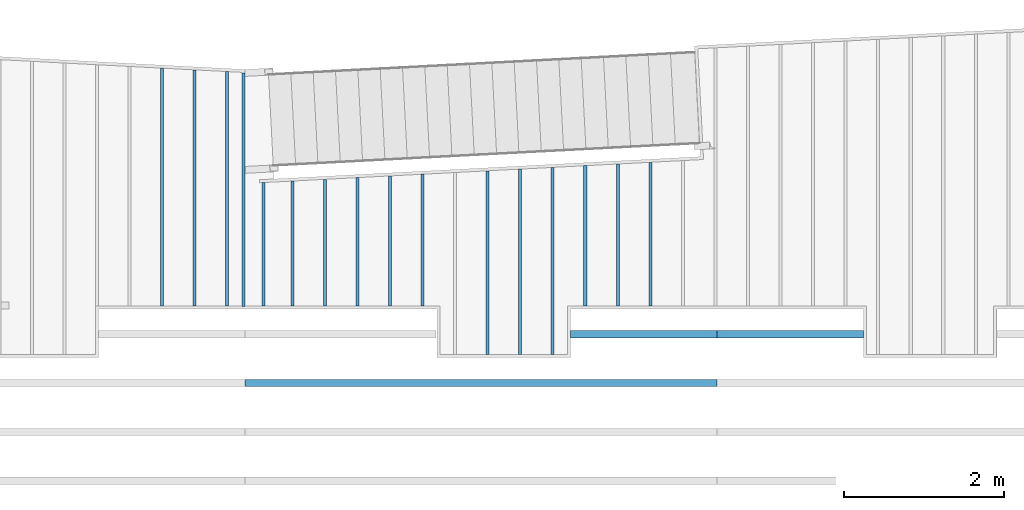
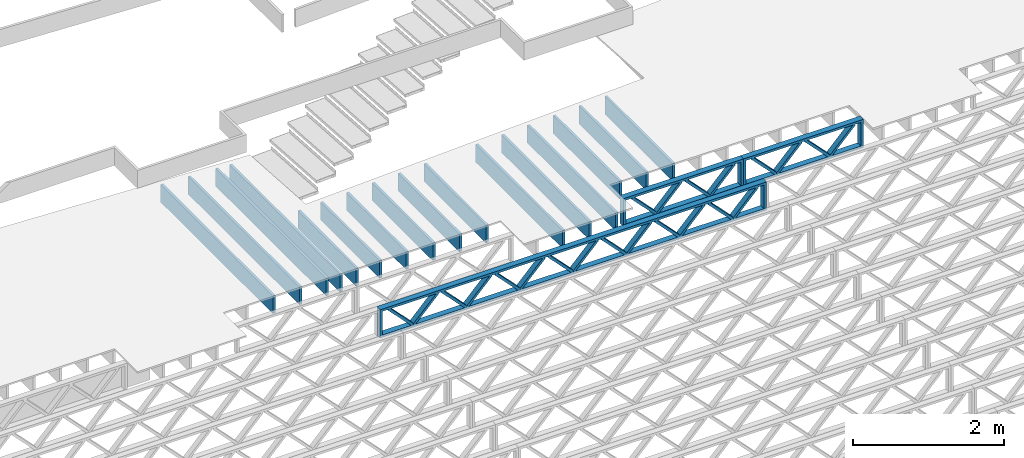
# One storey, part 5 of 23: 19 beams, 3 elements without a shape of their own.
"""IFC4 building model written with IfcOpenShell, lengths in feet."""

from ifc_helpers import new_model, entity, si_unit, converted_unit, derived_unit, direction, frame, frame_2d, origin, origin_2d_with_axis, place, context, subcontext, project, spatial, rectangle, extrude, source, transform, mapped, material, material_profile, profile_set, profile_usage, type_object, type_shapes, element, aggregate, save


model = new_model("IFC4")

# Units and contexts
model_context = context("Model", 3, precision=0.0001, world=origin(), true_north=direction((6.12303176911189e-17, 1.0)))
body_context = subcontext(model_context, "Body", "Model", "MODEL_VIEW")
ifc_project = project(units=[converted_unit("LENGTHUNIT", "FOOT", entity("IfcRatioMeasure", 0.3048), si_unit("LENGTHUNIT", "METRE"), dimensions=[1, 0, 0, 0, 0, 0, 0]), converted_unit("AREAUNIT", "SQUARE FOOT", entity("IfcRatioMeasure", 0.09290304), si_unit("AREAUNIT", "SQUARE_METRE"), dimensions=[2, 0, 0, 0, 0, 0, 0]), converted_unit("VOLUMEUNIT", "CUBIC FOOT", entity("IfcRatioMeasure", 0.028316846592), si_unit("VOLUMEUNIT", "CUBIC_METRE"), dimensions=[3, 0, 0, 0, 0, 0, 0]), converted_unit("PLANEANGLEUNIT", "DEGREE", entity("IfcRatioMeasure", 0.0174532925199433), si_unit("PLANEANGLEUNIT", "RADIAN"), dimensions=[0, 0, 0, 0, 0, 0, 0]), si_unit("MASSUNIT", "GRAM", prefix="KILO"), derived_unit("MASSDENSITYUNIT", [(si_unit("MASSUNIT", "GRAM", prefix="KILO"), 1), (si_unit("LENGTHUNIT", "METRE"), -3)]), derived_unit("MOMENTOFINERTIAUNIT", [(si_unit("LENGTHUNIT", "METRE"), 4)]), si_unit("TIMEUNIT", "SECOND"), si_unit("FREQUENCYUNIT", "HERTZ"), si_unit("THERMODYNAMICTEMPERATUREUNIT", "DEGREE_CELSIUS"), derived_unit("THERMALTRANSMITTANCEUNIT", [(si_unit("MASSUNIT", "GRAM", prefix="KILO"), 1), (si_unit("THERMODYNAMICTEMPERATUREUNIT", "KELVIN"), -1), (si_unit("TIMEUNIT", "SECOND"), -3)]), derived_unit("VOLUMETRICFLOWRATEUNIT", [(si_unit("LENGTHUNIT", "METRE"), 3), (si_unit("TIMEUNIT", "SECOND"), -1)]), si_unit("ELECTRICCURRENTUNIT", "AMPERE"), si_unit("ELECTRICVOLTAGEUNIT", "VOLT"), si_unit("POWERUNIT", "WATT"), si_unit("FORCEUNIT", "NEWTON"), si_unit("ILLUMINANCEUNIT", "LUX"), si_unit("LUMINOUSFLUXUNIT", "LUMEN"), si_unit("LUMINOUSINTENSITYUNIT", "CANDELA"), derived_unit("USERDEFINED", [(si_unit("MASSUNIT", "GRAM", prefix="KILO"), -1), (si_unit("LENGTHUNIT", "METRE"), -2), (si_unit("TIMEUNIT", "SECOND"), 3), (si_unit("LUMINOUSFLUXUNIT", "LUMEN"), 1)]), derived_unit("LINEARVELOCITYUNIT", [(si_unit("LENGTHUNIT", "METRE"), 1), (si_unit("TIMEUNIT", "SECOND"), -1)]), si_unit("PRESSUREUNIT", "PASCAL"), derived_unit("USERDEFINED", [(si_unit("LENGTHUNIT", "METRE"), -2), (si_unit("MASSUNIT", "GRAM", prefix="KILO"), 1), (si_unit("TIMEUNIT", "SECOND"), -2)]), derived_unit("LINEARFORCEUNIT", [(si_unit("MASSUNIT", "GRAM", prefix="KILO"), 1), (si_unit("LENGTHUNIT", "METRE"), 1), (si_unit("TIMEUNIT", "SECOND"), -2), (si_unit("LENGTHUNIT", "METRE"), -1)]), derived_unit("PLANARFORCEUNIT", [(si_unit("MASSUNIT", "GRAM", prefix="KILO"), 1), (si_unit("LENGTHUNIT", "METRE"), 1), (si_unit("TIMEUNIT", "SECOND"), -2), (si_unit("LENGTHUNIT", "METRE"), -2)])], contexts=[model_context])

# Site, building, storey
site_placement = place(None, origin())
site = spatial("IfcSite", under=ifc_project, at=site_placement, CompositionType="ELEMENT")
building_placement = place(site_placement, origin())
building = spatial("IfcBuilding", under=site, at=building_placement, CompositionType="ELEMENT")
storey_placement = place(building_placement, frame((0.0, 0.0, 10.8020833333333)))
storey = spatial("IfcBuildingStorey", under=building, at=storey_placement, Name="2ND FLOOR", CompositionType="ELEMENT", Elevation=10.8020833333333)

# Assembly, beams
assembly_1_placement = place(storey_placement, origin())
assembly_1 = element("IfcElementAssembly", 1, at=assembly_1_placement, inside=storey, Name="Structural Beam System:Structural Framing System", ObjectType="Structural Beam System:Structural Framing System", AssemblyPlace="NOTDEFINED", PredefinedType="BEAM_GRID")
ifc_material_1 = material(Name="WOOD TRUSS", Category="Materials")
ifc_material_profile_1 = material_profile(ifc_material_1, rectangle(XDim=1.73473973950632, YDim=0.125, at=frame_2d((-1.11022302462516e-16, 8.32667268468867e-17), x_axis=(1.0, 0.0))))
ifc_material_profile_2 = material_profile(ifc_material_1, rectangle(XDim=1.73473973950633, YDim=0.125, at=frame_2d((-1.11022302462516e-16, 8.32667268468867e-17), x_axis=(1.0, 0.0))))
ifc_material_profile_3 = material_profile(ifc_material_1, rectangle(XDim=1.73473973950632, YDim=0.125, at=frame_2d((-5.55111512312578e-17, 1.38777878078145e-16), x_axis=(1.0, 0.0))))
ifc_material_profile_4 = material_profile(ifc_material_1, rectangle(XDim=1.73473973950633, YDim=0.125, at=frame_2d((-1.11022302462516e-16, 8.32667268468867e-17), x_axis=(1.0, 0.0))))
ifc_material_profile_5 = material_profile(ifc_material_1, rectangle(XDim=1.73473973950632, YDim=0.125, at=frame_2d((-1.11022302462516e-16, 8.32667268468867e-17), x_axis=(1.0, 0.0))))
ifc_material_profile_6 = material_profile(ifc_material_1, rectangle(XDim=1.73473973950633, YDim=0.125, at=frame_2d((-2.77555756156289e-16, 3.05311331771918e-16), x_axis=(1.0, 0.0))))
ifc_material_profile_7 = material_profile(ifc_material_1, rectangle(XDim=1.73473973950632, YDim=0.124999999999999, at=frame_2d((-3.88578058618805e-16, -2.4980018054066e-16), x_axis=(1.0, 0.0))))
ifc_material_profile_8 = material_profile(ifc_material_1, rectangle(XDim=1.73473973950633, YDim=0.125, at=frame_2d((2.77555756156289e-16, -3.05311331771918e-16), x_axis=(1.0, 0.0))))
ifc_material_profile_9 = material_profile(ifc_material_1, rectangle(XDim=1.73473973950632, YDim=0.124999999999999, at=frame_2d((-1.11022302462516e-16, 8.32667268468867e-17), x_axis=(1.0, 0.0))))
ifc_material_profile_10 = material_profile(ifc_material_1, rectangle(XDim=1.73473973950633, YDim=0.125, at=origin_2d_with_axis()))
ifc_material_profile_11 = material_profile(ifc_material_1, rectangle(XDim=0.124999999999982, YDim=0.291666666666668, at=origin_2d_with_axis()))
ifc_material_profile_12 = material_profile(ifc_material_1, rectangle(XDim=0.124999999999932, YDim=0.291666666666664, at=origin_2d_with_axis()))
ifc_material_profile_13 = material_profile(ifc_material_1, rectangle(XDim=1.25000000000002, YDim=0.29166666666667, at=origin_2d_with_axis()))
ifc_material_profile_14 = material_profile(ifc_material_1, rectangle(XDim=1.25000000000004, YDim=0.291666666666667, at=origin_2d_with_axis()))
ifc_profile_set_1 = profile_set([ifc_material_profile_1, ifc_material_profile_2, ifc_material_profile_3, ifc_material_profile_4, ifc_material_profile_5, ifc_material_profile_6, ifc_material_profile_7, ifc_material_profile_8, ifc_material_profile_9, ifc_material_profile_10, ifc_material_profile_11, ifc_material_profile_12, ifc_material_profile_13, ifc_material_profile_14])
ifc_profile_usage_1 = profile_usage(ifc_profile_set_1, cardinal=8)
beam_type_1 = type_object("IfcBeamType", PredefinedType="BEAM", material=ifc_profile_set_1)
shared_shape_1 = source(origin(), body_context, "Body", "SweptSolid", [
    extrude(rectangle(XDim=1.73473973950632, YDim=0.125, at=frame_2d((0.0, 1.66533453693773e-16), x_axis=(1.0, 0.0))), frame((1.95847612494153, -0.145833333333334, 0.0), z_axis=(0.0, 1.0, 0.0), x_axis=(0.693383046997606, 0.0, 0.720569184836762)), (0.0, 0.0, 1.0), 0.291666666666667),
    extrude(rectangle(XDim=1.73473973950633, YDim=0.125, at=frame_2d((-5.55111512312578e-17, 8.32667268468867e-17), x_axis=(1.0, 0.0))), frame((0.708190251268258, -0.145833333333334, 0.0), z_axis=(0.0, 1.0, 0.0), x_axis=(0.69338304699761, 0.0, -0.720569184836758)), (0.0, 0.0, 1.0), 0.291666666666667),
    extrude(rectangle(XDim=1.73473973950632, YDim=0.125, at=frame_2d((0.0, 1.66533453693773e-16), x_axis=(1.0, 0.0))), frame((-0.708190251267602, -0.145833333333334, 0.0), z_axis=(0.0, 1.0, 0.0), x_axis=(0.693383046997606, 0.0, 0.720569184836762)), (0.0, 0.0, 1.0), 0.291666666666667),
    extrude(rectangle(XDim=1.73473973950633, YDim=0.125, at=frame_2d((-2.22044604925031e-16, 2.22044604925031e-16), x_axis=(1.0, 0.0))), frame((-1.95847612494087, -0.145833333333334, 0.0), z_axis=(0.0, 1.0, 0.0), x_axis=(0.69338304699761, 0.0, -0.720569184836758)), (0.0, 0.0, 1.0), 0.291666666666666),
    extrude(rectangle(XDim=0.124999999999982, YDim=0.291666666666668, at=origin_2d_with_axis()), frame((-2.99999985477115, 0.0, 0.687500000000054), z_axis=(1.0, 0.0, 0.0), x_axis=(0.0, 0.0, -1.0)), (0.0, 0.0, 1.0), 5.99999970954229),
    extrude(rectangle(XDim=0.124999999999932, YDim=0.291666666666664, at=origin_2d_with_axis()), frame((-2.99999985477093, 0.0, -0.687499999999984), z_axis=(1.0, 0.0, 0.0), x_axis=(0.0, 0.0, -1.0)), (0.0, 0.0, 1.0), 5.99999970954208),
    extrude(rectangle(XDim=1.25000000000002, YDim=0.29166666666667, at=origin_2d_with_axis()), frame((2.87499985477113, 0.0, 0.0), z_axis=(1.0, 0.0, 0.0), x_axis=(0.0, 0.0, -1.0)), (0.0, 0.0, 1.0), 0.12500000000002),
    extrude(rectangle(XDim=1.25000000000004, YDim=0.291666666666667, at=origin_2d_with_axis()), frame((-2.99999985477115, 0.0, 0.0), z_axis=(1.0, 0.0, 0.0), x_axis=(0.0, 0.0, -1.0)), (0.0, 0.0, 1.0), 0.125000000000023),
])
type_shapes(beam_type_1, [shared_shape_1])
beam_1_placement = place(assembly_1_placement, frame((-225.404826976829, 957.861934882651, -0.947916666666648)))
beam_1 = element("IfcBeam", 2, at=beam_1_placement, type_object=beam_type_1, material=ifc_profile_usage_1, PredefinedType="BEAM", context=body_context, shape_type="MappedRepresentation", body=[
    mapped(shared_shape_1, transform((0.0, 0.0, 0.0), scale=1.0)),
])
ifc_profile_usage_2 = profile_usage(ifc_profile_set_1, cardinal=8)
beam_type_2 = type_object("IfcBeamType", PredefinedType="BEAM", material=ifc_profile_set_1)
shared_shape_2 = source(origin(), body_context, "Body", "SweptSolid", [
    extrude(rectangle(XDim=1.73473973950632, YDim=0.124999999999999, at=frame_2d((5.55111512312578e-16, 7.21644966006352e-16), x_axis=(1.0, 0.0))), frame((5.95847627016997, -0.145833333333334, 0.0), z_axis=(0.0, 1.0, 0.0), x_axis=(0.693383046997606, 0.0, 0.720569184836762)), (0.0, 0.0, 1.0), 0.291666666666667),
    extrude(rectangle(XDim=1.73473973950633, YDim=0.125, at=origin_2d_with_axis()), frame((4.7081903964967, -0.145833333333334, 0.0), z_axis=(0.0, 1.0, 0.0), x_axis=(0.69338304699761, 0.0, -0.720569184836758)), (0.0, 0.0, 1.0), 0.291666666666666),
    extrude(rectangle(XDim=1.73473973950632, YDim=0.125, at=frame_2d((2.22044604925031e-16, 3.88578058618805e-16), x_axis=(1.0, 0.0))), frame((3.29180960350347, -0.145833333333334, 0.0), z_axis=(0.0, 1.0, 0.0), x_axis=(0.693383046997606, 0.0, 0.720569184836762)), (0.0, 0.0, 1.0), 0.291666666666667),
    extrude(rectangle(XDim=1.73473973950633, YDim=0.125, at=frame_2d((1.11022302462516e-16, -8.32667268468867e-17), x_axis=(1.0, 0.0))), frame((2.0415237298302, -0.145833333333334, 0.0), z_axis=(0.0, 1.0, 0.0), x_axis=(0.69338304699761, 0.0, -0.720569184836758)), (0.0, 0.0, 1.0), 0.291666666666667),
    extrude(rectangle(XDim=1.73473973950632, YDim=0.125, at=frame_2d((-5.55111512312578e-17, 1.38777878078145e-16), x_axis=(1.0, 0.0))), frame((0.625142936836964, -0.145833333333334, 0.0), z_axis=(0.0, 1.0, 0.0), x_axis=(0.693383046997606, 0.0, 0.720569184836762)), (0.0, 0.0, 1.0), 0.291666666666667),
    extrude(rectangle(XDim=1.73473973950633, YDim=0.125, at=frame_2d((-1.11022302462516e-16, 8.32667268468867e-17), x_axis=(1.0, 0.0))), frame((-0.625142936836306, -0.145833333333334, 0.0), z_axis=(0.0, 1.0, 0.0), x_axis=(0.69338304699761, 0.0, -0.720569184836758)), (0.0, 0.0, 1.0), 0.291666666666667),
    extrude(rectangle(XDim=1.73473973950632, YDim=0.125, at=frame_2d((-1.11022302462516e-16, 8.32667268468867e-17), x_axis=(1.0, 0.0))), frame((-2.04152372982954, -0.145833333333334, 0.0), z_axis=(0.0, 1.0, 0.0), x_axis=(0.693383046997606, 0.0, 0.720569184836762)), (0.0, 0.0, 1.0), 0.291666666666667),
    extrude(rectangle(XDim=1.73473973950633, YDim=0.125, at=origin_2d_with_axis()), frame((-3.29180960350281, -0.145833333333334, 0.0), z_axis=(0.0, 1.0, 0.0), x_axis=(0.69338304699761, 0.0, -0.720569184836758)), (0.0, 0.0, 1.0), 0.291666666666667),
    extrude(rectangle(XDim=1.73473973950632, YDim=0.124999999999999, at=frame_2d((-1.11022302462516e-16, 8.32667268468867e-17), x_axis=(1.0, 0.0))), frame((-4.70819039649604, -0.145833333333334, 0.0), z_axis=(0.0, 1.0, 0.0), x_axis=(0.693383046997606, 0.0, 0.720569184836762)), (0.0, 0.0, 1.0), 0.291666666666667),
    extrude(rectangle(XDim=1.73473973950633, YDim=0.125, at=frame_2d((-5.55111512312578e-16, 6.38378239159465e-16), x_axis=(1.0, 0.0))), frame((-5.95847627016931, -0.145833333333334, 0.0), z_axis=(0.0, 1.0, 0.0), x_axis=(0.69338304699761, 0.0, -0.720569184836758)), (0.0, 0.0, 1.0), 0.291666666666666),
    extrude(rectangle(XDim=1.73473973950632, YDim=0.125, at=frame_2d((-7.21644966006352e-16, -5.82867087928207e-16), x_axis=(1.0, 0.0))), frame((8.62514293683647, -0.145833333333334, 0.0), z_axis=(0.0, 1.0, 0.0), x_axis=(0.693383046997607, 0.0, 0.720569184836761)), (0.0, 0.0, 1.0), 0.291666666666667),
    extrude(rectangle(XDim=1.73473973950633, YDim=0.125, at=origin_2d_with_axis()), frame((7.3748570631632, -0.145833333333334, 0.0), z_axis=(0.0, 1.0, 0.0), x_axis=(0.69338304699761, 0.0, -0.720569184836758)), (0.0, 0.0, 1.0), 0.291666666666666),
    extrude(rectangle(XDim=1.73473973950632, YDim=0.124999999999999, at=frame_2d((-1.11022302462516e-16, 8.32667268468867e-17), x_axis=(1.0, 0.0))), frame((-7.37485706316255, -0.145833333333334, 0.0), z_axis=(0.0, 1.0, 0.0), x_axis=(0.693383046997606, 0.0, 0.720569184836762)), (0.0, 0.0, 1.0), 0.291666666666667),
    extrude(rectangle(XDim=1.73473973950633, YDim=0.125, at=origin_2d_with_axis()), frame((-8.62514293683582, -0.145833333333334, 0.0), z_axis=(0.0, 1.0, 0.0), x_axis=(0.69338304699761, 0.0, -0.720569184836758)), (0.0, 0.0, 1.0), 0.291666666666666),
    extrude(rectangle(XDim=0.124999999999982, YDim=0.291666666666668, at=origin_2d_with_axis()), frame((-9.66666666666609, 0.0, 0.687500000000054), z_axis=(1.0, 0.0, 0.0), x_axis=(0.0, 0.0, -1.0)), (0.0, 0.0, 1.0), 19.3333333333322),
    extrude(rectangle(XDim=0.124999999999932, YDim=0.291666666666664, at=origin_2d_with_axis()), frame((-9.66666666666588, 0.0, -0.687499999999984), z_axis=(1.0, 0.0, 0.0), x_axis=(0.0, 0.0, -1.0)), (0.0, 0.0, 1.0), 19.333333333332),
    extrude(rectangle(XDim=1.25000000000002, YDim=0.29166666666667, at=origin_2d_with_axis()), frame((9.54166666666607, 0.0, 0.0), z_axis=(1.0, 0.0, 0.0), x_axis=(0.0, 0.0, -1.0)), (0.0, 0.0, 1.0), 0.12500000000002),
    extrude(rectangle(XDim=1.25000000000004, YDim=0.291666666666667, at=origin_2d_with_axis()), frame((-9.66666666666609, 0.0, 0.0), z_axis=(1.0, 0.0, 0.0), x_axis=(0.0, 0.0, -1.0)), (0.0, 0.0, 1.0), 0.125000000000023),
])
type_shapes(beam_type_2, [shared_shape_2])
beam_2_placement = place(assembly_1_placement, frame((-232.071493788723, 955.861934882651, -0.947916666666657)))
beam_2 = element("IfcBeam", 3, at=beam_2_placement, type_object=beam_type_2, material=ifc_profile_usage_2, PredefinedType="BEAM", context=body_context, shape_type="MappedRepresentation", body=[
    mapped(shared_shape_2, transform((0.0, 0.0, 0.0), scale=1.0)),
])
aggregate(assembly_1, [beam_1, beam_2])

# Assembly, beam
assembly_2_placement = place(storey_placement, origin())
assembly_2 = element("IfcElementAssembly", 4, at=assembly_2_placement, inside=storey, Name="Structural Beam System:Structural Framing System", ObjectType="Structural Beam System:Structural Framing System", AssemblyPlace="NOTDEFINED", PredefinedType="BEAM_GRID")
ifc_profile_usage_3 = profile_usage(ifc_profile_set_1, cardinal=8)
beam_type_3 = type_object("IfcBeamType", PredefinedType="BEAM", material=ifc_profile_set_1)
shared_shape_3 = source(origin(), body_context, "Body", "SweptSolid", [
    extrude(rectangle(XDim=1.73473973950632, YDim=0.125, at=frame_2d((0.0, 1.66533453693773e-16), x_axis=(1.0, 0.0))), frame((1.95847610985504, -0.145833333333334, 0.0), z_axis=(0.0, 1.0, 0.0), x_axis=(0.693383046997606, 0.0, 0.720569184836762)), (0.0, 0.0, 1.0), 0.291666666666667),
    extrude(rectangle(XDim=1.73473973950633, YDim=0.125, at=frame_2d((-5.55111512312578e-17, 8.32667268468867e-17), x_axis=(1.0, 0.0))), frame((0.708190236181772, -0.145833333333334, 0.0), z_axis=(0.0, 1.0, 0.0), x_axis=(0.69338304699761, 0.0, -0.720569184836758)), (0.0, 0.0, 1.0), 0.291666666666667),
    extrude(rectangle(XDim=1.73473973950632, YDim=0.125, at=frame_2d((0.0, 1.66533453693773e-16), x_axis=(1.0, 0.0))), frame((-0.708190236181118, -0.145833333333334, 0.0), z_axis=(0.0, 1.0, 0.0), x_axis=(0.693383046997606, 0.0, 0.720569184836762)), (0.0, 0.0, 1.0), 0.291666666666667),
    extrude(rectangle(XDim=1.73473973950633, YDim=0.125, at=frame_2d((-2.22044604925031e-16, 2.22044604925031e-16), x_axis=(1.0, 0.0))), frame((-1.95847610985439, -0.145833333333334, 0.0), z_axis=(0.0, 1.0, 0.0), x_axis=(0.69338304699761, 0.0, -0.720569184836758)), (0.0, 0.0, 1.0), 0.291666666666666),
    extrude(rectangle(XDim=0.124999999999982, YDim=0.291666666666668, at=origin_2d_with_axis()), frame((-2.99999983968466, 0.0, 0.687500000000054), z_axis=(1.0, 0.0, 0.0), x_axis=(0.0, 0.0, -1.0)), (0.0, 0.0, 1.0), 5.99999967936932),
    extrude(rectangle(XDim=0.124999999999932, YDim=0.291666666666664, at=origin_2d_with_axis()), frame((-2.99999983968445, 0.0, -0.687499999999984), z_axis=(1.0, 0.0, 0.0), x_axis=(0.0, 0.0, -1.0)), (0.0, 0.0, 1.0), 5.99999967936911),
    extrude(rectangle(XDim=1.25000000000002, YDim=0.29166666666667, at=origin_2d_with_axis()), frame((2.87499983968464, 0.0, 0.0), z_axis=(1.0, 0.0, 0.0), x_axis=(0.0, 0.0, -1.0)), (0.0, 0.0, 1.0), 0.12500000000002),
    extrude(rectangle(XDim=1.25000000000004, YDim=0.291666666666667, at=origin_2d_with_axis()), frame((-2.99999983968466, 0.0, 0.0), z_axis=(1.0, 0.0, 0.0), x_axis=(0.0, 0.0, -1.0)), (0.0, 0.0, 1.0), 0.125000000000023),
])
type_shapes(beam_type_3, [shared_shape_3])
beam_3_placement = place(assembly_2_placement, frame((-219.404827312476, 957.861934882651, -0.947916666666872), z_axis=(0.0, 0.0, 1.0), x_axis=(-1.0, 0.0, 0.0)))
beam_3 = element("IfcBeam", 5, at=beam_3_placement, type_object=beam_type_3, material=ifc_profile_usage_3, PredefinedType="BEAM", context=body_context, shape_type="MappedRepresentation", body=[
    mapped(shared_shape_3, transform((0.0, 0.0, 0.0), scale=1.0)),
])
aggregate(assembly_2, [beam_3])

# Assembly, beams
assembly_3_placement = place(storey_placement, origin())
assembly_3 = element("IfcElementAssembly", 6, at=assembly_3_placement, inside=storey, Name="Structural Beam System:Structural Framing System", ObjectType="Structural Beam System:Structural Framing System", AssemblyPlace="NOTDEFINED", PredefinedType="BEAM_GRID")
ifc_material_2 = material(Category="Materials")
ifc_material_profile_15 = material_profile(ifc_material_2, rectangle(XDim=0.9375, YDim=0.125000000000011, at=origin_2d_with_axis()))
ifc_profile_set_2 = profile_set([ifc_material_profile_15])
ifc_profile_usage_4 = profile_usage(ifc_profile_set_2, cardinal=8)
beam_type_4 = type_object("IfcBeamType", PredefinedType="BEAM", material=ifc_profile_set_2)
shared_shape_4 = source(origin(), body_context, "Body", "SweptSolid", [
    extrude(rectangle(XDim=0.9375, YDim=0.125000000000011, at=origin_2d_with_axis()), frame((-4.86630502037076, 0.0, 0.0), z_axis=(1.0, 0.0, 0.0), x_axis=(0.0, 0.0, -1.0)), (0.0, 0.0, 1.0), 9.73261004074152),
])
type_shapes(beam_type_4, [shared_shape_4])
beam_4_placement = place(assembly_3_placement, frame((-245.133993818795, 963.894909190037, -0.729166666666744), z_axis=(0.0, 0.0, 1.0), x_axis=(0.0, 1.0, 0.0)))
beam_4 = element("IfcBeam", 7, at=beam_4_placement, type_object=beam_type_4, material=ifc_profile_usage_4, PredefinedType="BEAM", context=body_context, shape_type="MappedRepresentation", body=[
    mapped(shared_shape_4, transform((0.0, 0.0, 0.0), scale=1.0)),
])
ifc_profile_usage_5 = profile_usage(ifc_profile_set_2, cardinal=8)
beam_type_5 = type_object("IfcBeamType", PredefinedType="BEAM", material=ifc_profile_set_2)
shared_shape_5 = source(origin(), body_context, "Body", "SweptSolid", [
    extrude(rectangle(XDim=0.9375, YDim=0.125000000000011, at=origin_2d_with_axis()), frame((-4.83136650084879, 0.0, 0.0), z_axis=(1.0, 0.0, 0.0), x_axis=(0.0, 0.0, -1.0)), (0.0, 0.0, 1.0), 9.66273300169757),
])
type_shapes(beam_type_5, [shared_shape_5])
beam_5_placement = place(assembly_3_placement, frame((-243.800660485462, 963.859970670515, -0.729166666666744), z_axis=(0.0, 0.0, 1.0), x_axis=(0.0, 1.0, 0.0)))
beam_5 = element("IfcBeam", 8, at=beam_5_placement, type_object=beam_type_5, material=ifc_profile_usage_5, PredefinedType="BEAM", context=body_context, shape_type="MappedRepresentation", body=[
    mapped(shared_shape_5, transform((0.0, 0.0, 0.0), scale=1.0)),
])
ifc_profile_usage_6 = profile_usage(ifc_profile_set_2, cardinal=8)
beam_type_6 = type_object("IfcBeamType", PredefinedType="BEAM", material=ifc_profile_set_2)
shared_shape_6 = source(origin(), body_context, "Body", "SweptSolid", [
    extrude(rectangle(XDim=0.9375, YDim=0.125000000000011, at=origin_2d_with_axis()), frame((-4.79642798132676, 0.0, 0.0), z_axis=(1.0, 0.0, 0.0), x_axis=(0.0, 0.0, -1.0)), (0.0, 0.0, 1.0), 9.59285596265352),
])
type_shapes(beam_type_6, [shared_shape_6])
beam_6_placement = place(assembly_3_placement, frame((-242.467327152129, 963.825032150993, -0.729166666666744), z_axis=(0.0, 0.0, 1.0), x_axis=(0.0, 1.0, 0.0)))
beam_6 = element("IfcBeam", 9, at=beam_6_placement, type_object=beam_type_6, material=ifc_profile_usage_6, PredefinedType="BEAM", context=body_context, shape_type="MappedRepresentation", body=[
    mapped(shared_shape_6, transform((0.0, 0.0, 0.0), scale=1.0)),
])
ifc_profile_usage_7 = profile_usage(ifc_profile_set_2, cardinal=8)
beam_type_7 = type_object("IfcBeamType", PredefinedType="BEAM", material=ifc_profile_set_2)
shared_shape_7 = source(origin(), body_context, "Body", "SweptSolid", [
    extrude(rectangle(XDim=0.9375, YDim=0.125000000000011, at=origin_2d_with_axis()), frame((-2.55460024794093, 0.0, 0.0), z_axis=(1.0, 0.0, 0.0), x_axis=(0.0, 0.0, -1.0)), (0.0, 0.0, 1.0), 5.10920049588185),
])
type_shapes(beam_type_7, [shared_shape_7])
beam_7_placement = place(assembly_3_placement, frame((-239.800660485462, 961.583204417607, -0.729166666666744), z_axis=(0.0, 0.0, 1.0), x_axis=(0.0, 1.0, 0.0)))
beam_7 = element("IfcBeam", 10, at=beam_7_placement, type_object=beam_type_7, material=ifc_profile_usage_7, PredefinedType="BEAM", context=body_context, shape_type="MappedRepresentation", body=[
    mapped(shared_shape_7, transform((0.0, 0.0, 0.0), scale=1.0)),
])
ifc_profile_usage_8 = profile_usage(ifc_profile_set_2, cardinal=8)
beam_type_8 = type_object("IfcBeamType", PredefinedType="BEAM", material=ifc_profile_set_2)
shared_shape_8 = source(origin(), body_context, "Body", "SweptSolid", [
    extrude(rectangle(XDim=0.9375, YDim=0.125000000000011, at=origin_2d_with_axis()), frame((-2.58953876746284, 0.0, 0.0), z_axis=(1.0, 0.0, 0.0), x_axis=(0.0, 0.0, -1.0)), (0.0, 0.0, 1.0), 5.17907753492568),
])
type_shapes(beam_type_8, [shared_shape_8])
beam_8_placement = place(assembly_3_placement, frame((-238.467327152129, 961.618142937129, -0.729166666666744), z_axis=(0.0, 0.0, 1.0), x_axis=(0.0, 1.0, 0.0)))
beam_8 = element("IfcBeam", 11, at=beam_8_placement, type_object=beam_type_8, material=ifc_profile_usage_8, PredefinedType="BEAM", context=body_context, shape_type="MappedRepresentation", body=[
    mapped(shared_shape_8, transform((0.0, 0.0, 0.0), scale=1.0)),
])
ifc_profile_usage_9 = profile_usage(ifc_profile_set_2, cardinal=8)
beam_type_9 = type_object("IfcBeamType", PredefinedType="BEAM", material=ifc_profile_set_2)
shared_shape_9 = source(origin(), body_context, "Body", "SweptSolid", [
    extrude(rectangle(XDim=0.9375, YDim=0.125000000000011, at=origin_2d_with_axis()), frame((-2.62447728698476, 0.0, 0.0), z_axis=(1.0, 0.0, 0.0), x_axis=(0.0, 0.0, -1.0)), (0.0, 0.0, 1.0), 5.24895457396951),
])
type_shapes(beam_type_9, [shared_shape_9])
beam_9_placement = place(assembly_3_placement, frame((-237.133993818795, 961.653081456651, -0.729166666666744), z_axis=(0.0, 0.0, 1.0), x_axis=(0.0, 1.0, 0.0)))
beam_9 = element("IfcBeam", 12, at=beam_9_placement, type_object=beam_type_9, material=ifc_profile_usage_9, PredefinedType="BEAM", context=body_context, shape_type="MappedRepresentation", body=[
    mapped(shared_shape_9, transform((0.0, 0.0, 0.0), scale=1.0)),
])
ifc_profile_usage_10 = profile_usage(ifc_profile_set_2, cardinal=8)
beam_type_10 = type_object("IfcBeamType", PredefinedType="BEAM", material=ifc_profile_set_2)
shared_shape_10 = source(origin(), body_context, "Body", "SweptSolid", [
    extrude(rectangle(XDim=0.9375, YDim=0.125000000000011, at=origin_2d_with_axis()), frame((-2.65941580650667, 0.0, 0.0), z_axis=(1.0, 0.0, 0.0), x_axis=(0.0, 0.0, -1.0)), (0.0, 0.0, 1.0), 5.31883161301334),
])
type_shapes(beam_type_10, [shared_shape_10])
beam_10_placement = place(assembly_3_placement, frame((-235.800660485462, 961.688019976173, -0.729166666666744), z_axis=(0.0, 0.0, 1.0), x_axis=(0.0, 1.0, 0.0)))
beam_10 = element("IfcBeam", 13, at=beam_10_placement, type_object=beam_type_10, material=ifc_profile_usage_10, PredefinedType="BEAM", context=body_context, shape_type="MappedRepresentation", body=[
    mapped(shared_shape_10, transform((0.0, 0.0, 0.0), scale=1.0)),
])
ifc_profile_usage_11 = profile_usage(ifc_profile_set_2, cardinal=8)
beam_type_11 = type_object("IfcBeamType", PredefinedType="BEAM", material=ifc_profile_set_2)
shared_shape_11 = source(origin(), body_context, "Body", "SweptSolid", [
    extrude(rectangle(XDim=0.9375, YDim=0.125000000000011, at=origin_2d_with_axis()), frame((-2.69435432602859, 0.0, 0.0), z_axis=(1.0, 0.0, 0.0), x_axis=(0.0, 0.0, -1.0)), (0.0, 0.0, 1.0), 5.38870865205718),
])
type_shapes(beam_type_11, [shared_shape_11])
beam_11_placement = place(assembly_3_placement, frame((-234.467327152129, 961.722958495694, -0.729166666666744), z_axis=(0.0, 0.0, 1.0), x_axis=(0.0, 1.0, 0.0)))
beam_11 = element("IfcBeam", 14, at=beam_11_placement, type_object=beam_type_11, material=ifc_profile_usage_11, PredefinedType="BEAM", context=body_context, shape_type="MappedRepresentation", body=[
    mapped(shared_shape_11, transform((0.0, 0.0, 0.0), scale=1.0)),
])
ifc_profile_usage_12 = profile_usage(ifc_profile_set_2, cardinal=8)
beam_type_12 = type_object("IfcBeamType", PredefinedType="BEAM", material=ifc_profile_set_2)
shared_shape_12 = source(origin(), body_context, "Body", "SweptSolid", [
    extrude(rectangle(XDim=0.9375, YDim=0.125000000000011, at=origin_2d_with_axis()), frame((-3.76423267524643, 0.0, 0.0), z_axis=(1.0, 0.0, 0.0), x_axis=(0.0, 0.0, -1.0)), (0.0, 0.0, 1.0), 7.52846535049287),
])
type_shapes(beam_type_12, [shared_shape_12])
beam_12_placement = place(assembly_3_placement, frame((-231.800660485462, 960.792834224564, -0.729166666666744), z_axis=(0.0, 0.0, 1.0), x_axis=(0.0, 1.0, 0.0)))
beam_12 = element("IfcBeam", 15, at=beam_12_placement, type_object=beam_type_12, material=ifc_profile_usage_12, PredefinedType="BEAM", context=body_context, shape_type="MappedRepresentation", body=[
    mapped(shared_shape_12, transform((0.0, 0.0, 0.0), scale=1.0)),
])
ifc_profile_usage_13 = profile_usage(ifc_profile_set_2, cardinal=8)
beam_type_13 = type_object("IfcBeamType", PredefinedType="BEAM", material=ifc_profile_set_2)
shared_shape_13 = source(origin(), body_context, "Body", "SweptSolid", [
    extrude(rectangle(XDim=0.9375, YDim=0.125000000000011, at=origin_2d_with_axis()), frame((-3.79917119476829, 0.0, 0.0), z_axis=(1.0, 0.0, 0.0), x_axis=(0.0, 0.0, -1.0)), (0.0, 0.0, 1.0), 7.59834238953658),
])
type_shapes(beam_type_13, [shared_shape_13])
beam_13_placement = place(assembly_3_placement, frame((-230.467327152129, 960.827772744086, -0.729166666666744), z_axis=(0.0, 0.0, 1.0), x_axis=(0.0, 1.0, 0.0)))
beam_13 = element("IfcBeam", 16, at=beam_13_placement, type_object=beam_type_13, material=ifc_profile_usage_13, PredefinedType="BEAM", context=body_context, shape_type="MappedRepresentation", body=[
    mapped(shared_shape_13, transform((0.0, 0.0, 0.0), scale=1.0)),
])
ifc_profile_usage_14 = profile_usage(ifc_profile_set_2, cardinal=8)
beam_type_14 = type_object("IfcBeamType", PredefinedType="BEAM", material=ifc_profile_set_2)
shared_shape_14 = source(origin(), body_context, "Body", "SweptSolid", [
    extrude(rectangle(XDim=0.9375, YDim=0.125000000000011, at=origin_2d_with_axis()), frame((-3.83410971429021, 0.0, 0.0), z_axis=(1.0, 0.0, 0.0), x_axis=(0.0, 0.0, -1.0)), (0.0, 0.0, 1.0), 7.66821942858041),
])
type_shapes(beam_type_14, [shared_shape_14])
beam_14_placement = place(assembly_3_placement, frame((-229.133993818795, 960.862711263608, -0.729166666666744), z_axis=(0.0, 0.0, 1.0), x_axis=(0.0, 1.0, 0.0)))
beam_14 = element("IfcBeam", 17, at=beam_14_placement, type_object=beam_type_14, material=ifc_profile_usage_14, PredefinedType="BEAM", context=body_context, shape_type="MappedRepresentation", body=[
    mapped(shared_shape_14, transform((0.0, 0.0, 0.0), scale=1.0)),
])
ifc_profile_usage_15 = profile_usage(ifc_profile_set_2, cardinal=8)
beam_type_15 = type_object("IfcBeamType", PredefinedType="BEAM", material=ifc_profile_set_2)
shared_shape_15 = source(origin(), body_context, "Body", "SweptSolid", [
    extrude(rectangle(XDim=0.9375, YDim=0.125000000000011, at=origin_2d_with_axis()), frame((-2.86904661608258, 0.0, 0.0), z_axis=(1.0, 0.0, 0.0), x_axis=(0.0, 0.0, -1.0)), (0.0, 0.0, 1.0), 5.73809323216517),
])
type_shapes(beam_type_15, [shared_shape_15])
beam_15_placement = place(assembly_3_placement, frame((-227.800660485462, 961.89765140086, -0.729166666666744), z_axis=(0.0, 0.0, 1.0), x_axis=(0.0, 1.0, 0.0)))
beam_15 = element("IfcBeam", 18, at=beam_15_placement, type_object=beam_type_15, material=ifc_profile_usage_15, PredefinedType="BEAM", context=body_context, shape_type="MappedRepresentation", body=[
    mapped(shared_shape_15, transform((0.0, 0.0, 0.0), scale=1.0)),
])
ifc_profile_usage_16 = profile_usage(ifc_profile_set_2, cardinal=8)
beam_type_16 = type_object("IfcBeamType", PredefinedType="BEAM", material=ifc_profile_set_2)
shared_shape_16 = source(origin(), body_context, "Body", "SweptSolid", [
    extrude(rectangle(XDim=0.9375, YDim=0.125000000000011, at=origin_2d_with_axis()), frame((-2.90398529415785, 0.0, 0.0), z_axis=(1.0, 0.0, 0.0), x_axis=(0.0, 0.0, -1.0)), (0.0, 0.0, 1.0), 5.8079705883157),
])
type_shapes(beam_type_16, [shared_shape_16])
beam_16_placement = place(assembly_3_placement, frame((-226.467327152129, 961.932589761828, -0.729166666666744), z_axis=(0.0, 0.0, 1.0), x_axis=(0.0, 1.0, 0.0)))
beam_16 = element("IfcBeam", 19, at=beam_16_placement, type_object=beam_type_16, material=ifc_profile_usage_16, PredefinedType="BEAM", context=body_context, shape_type="MappedRepresentation", body=[
    mapped(shared_shape_16, transform((0.0, 0.0, 0.0), scale=1.0)),
])
ifc_profile_usage_17 = profile_usage(ifc_profile_set_2, cardinal=8)
beam_type_17 = type_object("IfcBeamType", PredefinedType="BEAM", material=ifc_profile_set_2)
shared_shape_17 = source(origin(), body_context, "Body", "SweptSolid", [
    extrude(rectangle(XDim=0.9375, YDim=0.125000000000011, at=origin_2d_with_axis()), frame((-2.93892397223317, 0.0, 0.0), z_axis=(1.0, 0.0, 0.0), x_axis=(0.0, 0.0, -1.0)), (0.0, 0.0, 1.0), 5.87784794446634),
])
type_shapes(beam_type_17, [shared_shape_17])
beam_17_placement = place(assembly_3_placement, frame((-225.133993818795, 961.967528122797, -0.729166666666744), z_axis=(0.0, 0.0, 1.0), x_axis=(0.0, 1.0, 0.0)))
beam_17 = element("IfcBeam", 20, at=beam_17_placement, type_object=beam_type_17, material=ifc_profile_usage_17, PredefinedType="BEAM", context=body_context, shape_type="MappedRepresentation", body=[
    mapped(shared_shape_17, transform((0.0, 0.0, 0.0), scale=1.0)),
])
aggregate(assembly_3, [beam_4, beam_5, beam_6, beam_7, beam_8, beam_9, beam_10, beam_11, beam_12, beam_13, beam_14, beam_15, beam_16, beam_17])

# Beams
ifc_profile_usage_18 = profile_usage(ifc_profile_set_2, cardinal=8)
beam_type_18 = type_object("IfcBeamType", PredefinedType="BEAM", material=ifc_profile_set_2)
shared_shape_18 = source(origin(), body_context, "Body", "SweptSolid", [
    extrude(rectangle(XDim=0.9375, YDim=0.125000000000011, at=frame_2d((-8.32667268468867e-17, 0.0), x_axis=(1.0, 0.0))), frame((-2.52389187218054, 0.0, 0.0), z_axis=(1.0, 0.0, 0.0), x_axis=(0.0, 0.0, -1.0)), (0.0, 0.0, 1.0), 5.04778374436108),
])
type_shapes(beam_type_18, [shared_shape_18])
beam_18_placement = place(storey_placement, frame((-240.972506076923, 961.552497128989, -0.729166666666742), z_axis=(0.0, 0.0, 1.0), x_axis=(-1.39070708966994e-05, 1.0, 0.0)))
element("IfcBeam", 21, at=beam_18_placement, inside=storey, type_object=beam_type_18, material=ifc_profile_usage_18, PredefinedType="BEAM", context=body_context, shape_type="MappedRepresentation", body=[
    mapped(shared_shape_18, transform((0.0, 0.0, 0.0), scale=1.0)),
])
ifc_profile_usage_19 = profile_usage(ifc_profile_set_2, cardinal=8)
beam_type_19 = type_object("IfcBeamType", PredefinedType="BEAM", material=ifc_profile_set_2)
shared_shape_19 = source(origin(), body_context, "Body", "SweptSolid", [
    extrude(rectangle(XDim=0.9375, YDim=0.125000000000011, at=origin_2d_with_axis()), frame((-4.78526668789971, 0.0, 0.0), z_axis=(1.0, 0.0, 0.0), x_axis=(0.0, 0.0, -1.0)), (0.0, 0.0, 1.0), 9.57053337579941),
])
type_shapes(beam_type_19, [shared_shape_19])
beam_19_placement = place(storey_placement, frame((-241.800660485529, 963.778932338047, -0.729166666666744), z_axis=(0.0, 0.0, 1.0), x_axis=(0.0, 1.0, 0.0)))
element("IfcBeam", 22, at=beam_19_placement, inside=storey, type_object=beam_type_19, material=ifc_profile_usage_19, PredefinedType="BEAM", context=body_context, shape_type="MappedRepresentation", body=[
    mapped(shared_shape_19, transform((0.0, 0.0, 0.0), scale=1.0)),
])

save(model, "model.ifc")
